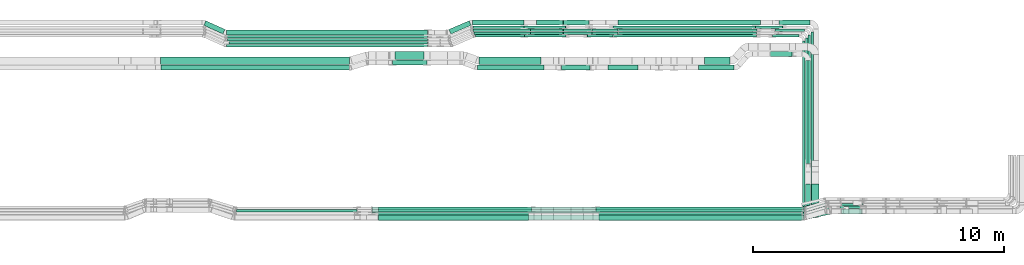
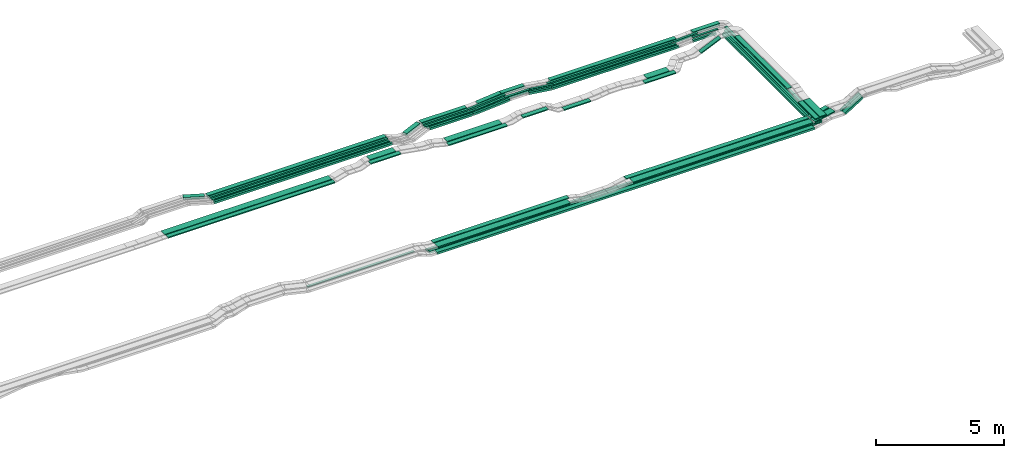
# One storey, part 2 of 31: 64 flow segments.
"""IFC2X3 building model written with IfcOpenShell, lengths in millimetres."""

from ifc_helpers import new_model, entity, si_unit, converted_unit, derived_unit, direction, frame, frame_2d, origin, origin_2d_with_axis, place, context, subcontext, project, spatial, rectangle, extrude, type_object, element, save


model = new_model("IFC2X3")

# Units and contexts
model_context = context("Model", 3, precision=0.01, world=origin(), true_north=direction((6.12303176911189e-17, 1.0)))
body_context = subcontext(model_context, "Body", "Model", "MODEL_VIEW")
ifc_project = project(units=[si_unit("LENGTHUNIT", "METRE", prefix="MILLI"), si_unit("AREAUNIT", "SQUARE_METRE"), si_unit("VOLUMEUNIT", "CUBIC_METRE"), converted_unit("PLANEANGLEUNIT", "DEGREE", entity("IfcRatioMeasure", 0.0174532925199433), si_unit("PLANEANGLEUNIT", "RADIAN"), dimensions=[0, 0, 0, 0, 0, 0, 0]), si_unit("MASSUNIT", "GRAM", prefix="KILO"), derived_unit("MASSDENSITYUNIT", [(si_unit("MASSUNIT", "GRAM", prefix="KILO"), 1), (si_unit("LENGTHUNIT", "METRE"), -3)]), derived_unit("MOMENTOFINERTIAUNIT", [(si_unit("LENGTHUNIT", "METRE"), 4)]), si_unit("TIMEUNIT", "SECOND"), si_unit("FREQUENCYUNIT", "HERTZ"), si_unit("THERMODYNAMICTEMPERATUREUNIT", "DEGREE_CELSIUS"), derived_unit("THERMALTRANSMITTANCEUNIT", [(si_unit("MASSUNIT", "GRAM", prefix="KILO"), 1), (si_unit("THERMODYNAMICTEMPERATUREUNIT", "KELVIN"), -1), (si_unit("TIMEUNIT", "SECOND"), -3)]), derived_unit("VOLUMETRICFLOWRATEUNIT", [(si_unit("LENGTHUNIT", "METRE"), 3), (si_unit("TIMEUNIT", "SECOND"), -1)]), derived_unit("MASSFLOWRATEUNIT", [(si_unit("MASSUNIT", "GRAM", prefix="KILO"), 1), (si_unit("TIMEUNIT", "SECOND"), -1)]), derived_unit("ROTATIONALFREQUENCYUNIT", [(si_unit("TIMEUNIT", "SECOND"), -1)]), si_unit("ELECTRICCURRENTUNIT", "AMPERE"), si_unit("ELECTRICVOLTAGEUNIT", "VOLT"), si_unit("POWERUNIT", "WATT"), si_unit("FORCEUNIT", "NEWTON", prefix="KILO"), si_unit("ILLUMINANCEUNIT", "LUX"), si_unit("LUMINOUSFLUXUNIT", "LUMEN"), si_unit("LUMINOUSINTENSITYUNIT", "CANDELA"), derived_unit("USERDEFINED", [(si_unit("MASSUNIT", "GRAM", prefix="KILO"), -1), (si_unit("LENGTHUNIT", "METRE"), -2), (si_unit("TIMEUNIT", "SECOND"), 3), (si_unit("LUMINOUSFLUXUNIT", "LUMEN"), 1)]), derived_unit("LINEARVELOCITYUNIT", [(si_unit("LENGTHUNIT", "METRE"), 1), (si_unit("TIMEUNIT", "SECOND"), -1)]), si_unit("PRESSUREUNIT", "PASCAL"), derived_unit("USERDEFINED", [(si_unit("LENGTHUNIT", "METRE"), -2), (si_unit("MASSUNIT", "GRAM", prefix="KILO"), 1), (si_unit("TIMEUNIT", "SECOND"), -2)]), derived_unit("LINEARFORCEUNIT", [(si_unit("MASSUNIT", "GRAM", prefix="KILO"), 1), (si_unit("LENGTHUNIT", "METRE"), 1), (si_unit("TIMEUNIT", "SECOND"), -2), (si_unit("LENGTHUNIT", "METRE"), -1)]), derived_unit("PLANARFORCEUNIT", [(si_unit("MASSUNIT", "GRAM", prefix="KILO"), 1), (si_unit("LENGTHUNIT", "METRE"), 1), (si_unit("TIMEUNIT", "SECOND"), -2), (si_unit("LENGTHUNIT", "METRE"), -2)])], contexts=[model_context])

# Site, building, storey
site_placement = place(None, frame((0.0, -0.00077364408347762, 0.0)))
site = spatial("IfcSite", under=ifc_project, at=site_placement, CompositionType="ELEMENT")
building_placement = place(site_placement, origin())
building = spatial("IfcBuilding", under=site, at=building_placement, CompositionType="ELEMENT")
storey_placement = place(building_placement, frame((0.0, 0.0, 15900.0)))
storey = spatial("IfcBuildingStorey", under=building, at=storey_placement, CompositionType="ELEMENT", Elevation=15900.0)

# Flow segments
cable_carrier_segment_type = type_object("IfcCableCarrierSegmentType", PredefinedType="CABLETRAYSEGMENT")
flow_segment_1_placement = place(storey_placement, frame((60126.0767428682, 8284.99390899462, 2660.0)))
element("IfcFlowSegment", 1, at=flow_segment_1_placement, inside=storey, type_object=cable_carrier_segment_type, context=body_context, shape_type="SweptSolid", body=[
    extrude(rectangle(XDim=7079.00000000001, YDim=99.9999999999946, at=frame_2d((-6.82121026329696e-13, 0.0), x_axis=(1.0, 0.0))), frame((50.0, 3539.50000000001, 0.0), z_axis=(0.0, 0.0, 1.0), x_axis=(0.0, -1.0, 0.0)), (0.0, 0.0, 1.0), 99.9999999999989),
])
flow_segment_2_placement = place(storey_placement, frame((60236.0767428682, 8299.45800005181, 2660.19015606754)))
element("IfcFlowSegment", 2, at=flow_segment_2_placement, inside=storey, type_object=cable_carrier_segment_type, context=body_context, shape_type="SweptSolid", body=[
    extrude(rectangle(XDim=7179.00000000001, YDim=99.9999999999946, at=origin_2d_with_axis()), frame((50.0, 3589.50000000001, 0.0), z_axis=(0.0, 0.0, 1.0), x_axis=(0.0, -1.0, 0.0)), (0.0, 0.0, 1.0), 50.0000000000016),
])
flow_segment_3_placement = place(storey_placement, frame((60346.0767428682, 8299.99390899457, 2660.1950842816)))
element("IfcFlowSegment", 3, at=flow_segment_3_placement, inside=storey, type_object=cable_carrier_segment_type, context=body_context, shape_type="SweptSolid", body=[
    extrude(rectangle(XDim=7298.46409105725, YDim=99.9999999999946, at=frame_2d((1.13686837721616e-12, 0.0), x_axis=(1.0, 0.0))), frame((50.0, 3649.23204552863, 0.0), z_axis=(0.0, 0.0, 1.0), x_axis=(0.0, -1.0, 0.0)), (0.0, 0.0, 1.0), 50.0000000000016),
])
flow_segment_4_placement = place(storey_placement, frame((37560.2402796495, 8544.96624585789, 2710.63734545372)))
element("IfcFlowSegment", 4, at=flow_segment_4_placement, inside=storey, type_object=cable_carrier_segment_type, context=body_context, shape_type="SweptSolid", body=[
    extrude(rectangle(XDim=4809.76682509451, YDim=100.000000000001, at=frame_2d((-4.32009983342141e-12, 5.43565192856477e-13), x_axis=(1.0, 0.0))), frame((2404.88341254725, 50.0, 0.0), z_axis=(0.0, 0.0, 1.0), x_axis=(-1.0, 0.0, 0.0)), (0.0, 0.0, 1.0), 50.0000000000016),
])
flow_segment_5_placement = place(storey_placement, frame((43221.6769225087, 8550.14880665483, 2820.0)))
element("IfcFlowSegment", 5, at=flow_segment_5_placement, inside=storey, type_object=cable_carrier_segment_type, context=body_context, shape_type="SweptSolid", body=[
    extrude(rectangle(XDim=6093.02235435077, YDim=200.0, at=origin_2d_with_axis()), frame((3046.51117717539, 100.0, 0.0), z_axis=(0.0, 0.0, 1.0), x_axis=(-1.0, 0.0, 0.0)), (0.0, 0.0, 1.0), 50.0000000000016),
])
flow_segment_6_placement = place(storey_placement, frame((43231.4788097309, 8215.14880665483, 2820.0)))
element("IfcFlowSegment", 6, at=flow_segment_6_placement, inside=storey, type_object=cable_carrier_segment_type, context=body_context, shape_type="SweptSolid", body=[
    extrude(rectangle(XDim=5963.81419063151, YDim=300.000000000001, at=frame_2d((4.32009983342141e-12, 5.40012479177676e-13), x_axis=(1.0, 0.0))), frame((2981.90709531576, 150.0, 0.0), z_axis=(0.0, 0.0, 1.0), x_axis=(-1.0, 0.0, 0.0)), (0.0, 0.0, 1.0), 50.0000000000016),
])
flow_segment_7_placement = place(storey_placement, frame((51889.3819158847, 8550.14880665474, 2820.0)))
element("IfcFlowSegment", 7, at=flow_segment_7_placement, inside=storey, type_object=cable_carrier_segment_type, context=body_context, shape_type="SweptSolid", body=[
    extrude(rectangle(XDim=8214.82266002888, YDim=200.0, at=origin_2d_with_axis()), frame((4107.41133001444, 100.0, 0.0)), (0.0, 0.0, 1.0), 50.0000000000016),
])
flow_segment_8_placement = place(storey_placement, frame((52008.9391584267, 8215.14880665474, 2820.0)))
element("IfcFlowSegment", 8, at=flow_segment_8_placement, inside=storey, type_object=cable_carrier_segment_type, context=body_context, shape_type="SweptSolid", body=[
    extrude(rectangle(XDim=8089.55955573693, YDim=300.000000000001, at=origin_2d_with_axis()), frame((4044.77977786846, 150.0, 0.0)), (0.0, 0.0, 1.0), 50.0000000000016),
])
flow_segment_9_placement = place(storey_placement, frame((42966.1590271839, 8654.96624585788, 2495.02366929601)))
element("IfcFlowSegment", 9, at=flow_segment_9_placement, inside=storey, type_object=cable_carrier_segment_type, context=body_context, shape_type="SweptSolid", body=[
    extrude(rectangle(XDim=17232.0585205176, YDim=100.000000000001, at=frame_2d((-3.63797880709171e-12, 5.43565192856477e-13), x_axis=(1.0, 0.0))), frame((8616.02926025879, 50.0, 0.0)), (0.0, 0.0, 1.0), 50.0000000000016),
])
flow_segment_10_placement = place(storey_placement, frame((42969.9115447475, 8544.96624585788, 2495.0546523344)))
element("IfcFlowSegment", 10, at=flow_segment_10_placement, inside=storey, type_object=cable_carrier_segment_type, context=body_context, shape_type="SweptSolid", body=[
    extrude(rectangle(XDim=17228.3060029539, YDim=100.000000000001, at=frame_2d((-4.54747350886464e-12, 5.43565192856477e-13), x_axis=(1.0, 0.0))), frame((8614.15300147695, 50.0, 0.0)), (0.0, 0.0, 1.0), 50.0000000000016),
])
flow_segment_11_placement = place(storey_placement, frame((42969.0456174009, 8434.96624585777, 2500.0)))
element("IfcFlowSegment", 11, at=flow_segment_11_placement, inside=storey, type_object=cable_carrier_segment_type, context=body_context, shape_type="SweptSolid", body=[
    extrude(rectangle(XDim=17229.1719303005, YDim=99.9999999999989, at=origin_2d_with_axis()), frame((8614.58596515024, 50.0, 0.0)), (0.0, 0.0, 1.0), 99.9999999999989),
])
flow_segment_12_placement = place(storey_placement, frame((43203.4612084207, 8224.96624585778, 2500.0)))
element("IfcFlowSegment", 12, at=flow_segment_12_placement, inside=storey, type_object=cable_carrier_segment_type, context=body_context, shape_type="SweptSolid", body=[
    extrude(rectangle(XDim=16981.1662330708, YDim=200.0, at=frame_2d((-4.54747350886464e-12, -5.47117906535277e-13), x_axis=(1.0, 0.0))), frame((8490.58311653538, 100.0, 0.0)), (0.0, 0.0, 1.0), 99.9999999999968),
])
flow_segment_13_placement = place(storey_placement, frame((60142.3221565162, 8560.70428769461, 2820.0)))
element("IfcFlowSegment", 13, at=flow_segment_13_placement, inside=storey, type_object=cable_carrier_segment_type, context=body_context, shape_type="SweptSolid", body=[
    extrude(rectangle(XDim=974.281376760203, YDim=200.000000000001, at=frame_2d((-1.4210854715202e-13, -5.40012479177676e-13), x_axis=(1.0, 0.0))), frame((496.882685052164, 214.444327228766, 0.0), z_axis=(0.0, 0.0, 1.0), x_axis=(-0.970529997992859, -0.240980337363821, 0.0)), (0.0, 0.0, 1.0), 50.0000000000016),
])
flow_segment_14_placement = place(storey_placement, frame((60133.7239929422, 8226.56545636169, 2820.0)))
element("IfcFlowSegment", 14, at=flow_segment_14_placement, inside=storey, type_object=cable_carrier_segment_type, context=body_context, shape_type="SweptSolid", body=[
    extrude(rectangle(XDim=1058.47458946237, YDim=300.000000000004, at=origin_2d_with_axis()), frame((549.321224610694, 263.583158561679, 0.0), z_axis=(0.0, 0.0, 1.0), x_axis=(-0.975122262229243, -0.221667710108901, 0.0)), (0.0, 0.0, 1.0), 50.0000000000016),
])
flow_segment_15_placement = place(storey_placement, frame((34536.9675359055, 14435.0255085139, 2675.0)))
element("IfcFlowSegment", 15, at=flow_segment_15_placement, inside=storey, type_object=cable_carrier_segment_type, context=body_context, shape_type="SweptSolid", body=[
    extrude(rectangle(XDim=7521.02349391717, YDim=300.000000000001, at=frame_2d((-2.27373675443232e-12, 0.0), x_axis=(1.0, 0.0))), frame((3760.51174695859, 150.0, 0.0), z_axis=(0.0, 0.0, 1.0), x_axis=(-1.0, 0.0, 0.0)), (0.0, 0.0, 1.0), 50.0000000000016),
])
flow_segment_16_placement = place(storey_placement, frame((34556.9248240395, 14200.0255085139, 2675.0)))
element("IfcFlowSegment", 16, at=flow_segment_16_placement, inside=storey, type_object=cable_carrier_segment_type, context=body_context, shape_type="SweptSolid", body=[
    extrude(rectangle(XDim=7508.26665724989, YDim=199.999999999998, at=origin_2d_with_axis()), frame((3754.13332862494, 100.0, 0.0), z_axis=(0.0, 0.0, 1.0), x_axis=(-1.0, 0.0, 0.0)), (0.0, 0.0, 1.0), 50.0000000000016),
])
flow_segment_17_placement = place(storey_placement, frame((47238.0928081156, 14435.0255085139, 2650.0)))
element("IfcFlowSegment", 17, at=flow_segment_17_placement, inside=storey, type_object=cable_carrier_segment_type, context=body_context, shape_type="SweptSolid", body=[
    extrude(rectangle(XDim=2472.10759373964, YDim=300.000000000001, at=frame_2d((0.0, 1.08002495835535e-12), x_axis=(1.0, 0.0))), frame((1236.05379686982, 150.0, 0.0)), (0.0, 0.0, 1.0), 50.0000000000016),
])
flow_segment_18_placement = place(storey_placement, frame((37169.4687962586, 15609.9939089947, 2835.0)))
element("IfcFlowSegment", 18, at=flow_segment_18_placement, inside=storey, type_object=cable_carrier_segment_type, context=body_context, shape_type="SweptSolid", body=[
    extrude(rectangle(XDim=8013.73124229196, YDim=200.000000000002, at=frame_2d((-4.32009983342141e-12, 0.0), x_axis=(1.0, 0.0))), frame((4006.86562114598, 100.0, 0.0)), (0.0, 0.0, 1.0), 99.9999999999989),
])
flow_segment_19_placement = place(storey_placement, frame((37186.1261928913, 15479.9939089947, 2835.0)))
element("IfcFlowSegment", 19, at=flow_segment_19_placement, inside=storey, type_object=cable_carrier_segment_type, context=body_context, shape_type="SweptSolid", body=[
    extrude(rectangle(XDim=7996.88069095725, YDim=99.9999999999989, at=frame_2d((-2.27373675443232e-12, 1.08357767203415e-12), x_axis=(1.0, 0.0))), frame((3998.44034547862, 50.0, 0.0)), (0.0, 0.0, 1.0), 99.9999999999989),
])
flow_segment_20_placement = place(storey_placement, frame((37201.5450950808, 15359.4580000518, 2838.00113012667)))
element("IfcFlowSegment", 20, at=flow_segment_20_placement, inside=storey, type_object=cable_carrier_segment_type, context=body_context, shape_type="SweptSolid", body=[
    extrude(rectangle(XDim=7980.27118863344, YDim=99.9999999999989, at=frame_2d((-2.04636307898909e-12, -1.08357767203415e-12), x_axis=(1.0, 0.0))), frame((3990.13559431672, 50.0, 0.0)), (0.0, 0.0, 1.0), 50.0000000000016),
])
flow_segment_21_placement = place(storey_placement, frame((37267.0183213648, 15239.4580000518, 2838.00113012699)))
element("IfcFlowSegment", 21, at=flow_segment_21_placement, inside=storey, type_object=cable_carrier_segment_type, context=body_context, shape_type="SweptSolid", body=[
    extrude(rectangle(XDim=7914.79796234961, YDim=99.9999999999989, at=frame_2d((0.0, 1.08357767203415e-12), x_axis=(1.0, 0.0))), frame((3957.3989811748, 50.0, 0.0)), (0.0, 0.0, 1.0), 50.0000000000016),
])
flow_segment_22_placement = place(storey_placement, frame((37164.5534838252, 15124.9939089947, 2834.95683445176)))
element("IfcFlowSegment", 22, at=flow_segment_22_placement, inside=storey, type_object=cable_carrier_segment_type, context=body_context, shape_type="SweptSolid", body=[
    extrude(rectangle(XDim=8018.77837251078, YDim=99.9999999999989, at=frame_2d((-4.32009983342141e-12, 0.0), x_axis=(1.0, 0.0))), frame((4009.38918625539, 50.0, 0.0), z_axis=(0.0, 0.0, 1.0), x_axis=(-1.0, 0.0, 0.0)), (0.0, 0.0, 1.0), 99.9999999999989),
])
flow_segment_23_placement = place(storey_placement, frame((46977.5480949237, 15999.9939089947, 2635.0)))
element("IfcFlowSegment", 23, at=flow_segment_23_placement, inside=storey, type_object=cable_carrier_segment_type, context=body_context, shape_type="SweptSolid", body=[
    extrude(rectangle(XDim=2052.75232011683, YDim=199.999999999998, at=frame_2d((4.32009983342141e-12, 1.08002495835535e-12), x_axis=(1.0, 0.0))), frame((1026.37616005842, 100.0, 0.0)), (0.0, 0.0, 1.0), 99.9999999999989),
])
flow_segment_24_placement = place(storey_placement, frame((46985.5606503717, 15869.9939089947, 2635.0)))
element("IfcFlowSegment", 24, at=flow_segment_24_placement, inside=storey, type_object=cable_carrier_segment_type, context=body_context, shape_type="SweptSolid", body=[
    extrude(rectangle(XDim=2041.44898293753, YDim=99.9999999999989, at=frame_2d((4.32009983342141e-12, 1.08357767203415e-12), x_axis=(1.0, 0.0))), frame((1020.72449146877, 50.0, 0.0)), (0.0, 0.0, 1.0), 99.9999999999989),
])
flow_segment_25_placement = place(storey_placement, frame((46985.5606503717, 15749.4580000518, 2637.24472037611)))
element("IfcFlowSegment", 25, at=flow_segment_25_placement, inside=storey, type_object=cable_carrier_segment_type, context=body_context, shape_type="SweptSolid", body=[
    extrude(rectangle(XDim=2290.66032248258, YDim=99.9999999999989, at=frame_2d((0.0, 1.08357767203415e-12), x_axis=(1.0, 0.0))), frame((1145.33016124129, 50.0, 0.0)), (0.0, 0.0, 1.0), 50.0000000000016),
])
flow_segment_26_placement = place(storey_placement, frame((47028.2259722805, 15629.4580000518, 2637.24472037609)))
element("IfcFlowSegment", 26, at=flow_segment_26_placement, inside=storey, type_object=cable_carrier_segment_type, context=body_context, shape_type="SweptSolid", body=[
    extrude(rectangle(XDim=2247.99500057377, YDim=99.9999999999989, at=frame_2d((0.0, 1.08357767203415e-12), x_axis=(1.0, 0.0))), frame((1123.99750028689, 50.0, 0.0), z_axis=(0.0, 0.0, 1.0), x_axis=(-1.0, 0.0, 0.0)), (0.0, 0.0, 1.0), 50.0000000000016),
])
flow_segment_27_placement = place(storey_placement, frame((47088.2259722794, 15514.9939089947, 2634.94956318967)))
element("IfcFlowSegment", 27, at=flow_segment_27_placement, inside=storey, type_object=cable_carrier_segment_type, context=body_context, shape_type="SweptSolid", body=[
    extrude(rectangle(XDim=1946.15966005004, YDim=99.9999999999989, at=frame_2d((4.32009983342141e-12, 1.08357767203415e-12), x_axis=(1.0, 0.0))), frame((973.079830025015, 50.0, 0.0), z_axis=(0.0, 0.0, 1.0), x_axis=(-1.0, 0.0, 0.0)), (0.0, 0.0, 1.0), 99.9999999999989),
])
flow_segment_28_placement = place(storey_placement, frame((50592.288789294, 15999.9939089947, 2760.0)))
element("IfcFlowSegment", 28, at=flow_segment_28_placement, inside=storey, type_object=cable_carrier_segment_type, context=body_context, shape_type="SweptSolid", body=[
    extrude(rectangle(XDim=1023.30452444504, YDim=200.000000000002, at=frame_2d((0.0, 1.08713038571295e-12), x_axis=(1.0, 0.0))), frame((511.65226222252, 100.0, 0.0), z_axis=(0.0, 0.0, 1.0), x_axis=(-1.0, 0.0, 0.0)), (0.0, 0.0, 1.0), 99.9999999999989),
])
flow_segment_29_placement = place(storey_placement, frame((50590.7420026315, 15749.4580000518, 2762.19977544195)))
element("IfcFlowSegment", 29, at=flow_segment_29_placement, inside=storey, type_object=cable_carrier_segment_type, context=body_context, shape_type="SweptSolid", body=[
    extrude(rectangle(XDim=1131.59489516369, YDim=99.9999999999989, at=origin_2d_with_axis()), frame((565.797447581843, 50.0, 0.0), z_axis=(0.0, 0.0, 1.0), x_axis=(-1.0, 0.0, 0.0)), (0.0, 0.0, 1.0), 50.0000000000016),
])
flow_segment_30_placement = place(storey_placement, frame((50590.7420026315, 15629.4580000518, 2762.19977544195)))
element("IfcFlowSegment", 30, at=flow_segment_30_placement, inside=storey, type_object=cable_carrier_segment_type, context=body_context, shape_type="SweptSolid", body=[
    extrude(rectangle(XDim=1135.49890513971, YDim=99.9999999999989, at=frame_2d((-4.32009983342141e-12, 0.0), x_axis=(1.0, 0.0))), frame((567.749452569852, 50.0, 0.0), z_axis=(0.0, 0.0, 1.0), x_axis=(-1.0, 0.0, 0.0)), (0.0, 0.0, 1.0), 50.0000000000016),
])
flow_segment_31_placement = place(storey_placement, frame((52778.7987899668, 15999.9939089946, 2615.0)))
element("IfcFlowSegment", 31, at=flow_segment_31_placement, inside=storey, type_object=cable_carrier_segment_type, context=body_context, shape_type="SweptSolid", body=[
    extrude(rectangle(XDim=5664.14517649834, YDim=200.000000000002, at=origin_2d_with_axis()), frame((2832.07258824917, 100.0, 0.0)), (0.0, 0.0, 1.0), 100.000000000001),
])
flow_segment_32_placement = place(storey_placement, frame((52567.1472057235, 15869.9939089946, 2615.0)))
element("IfcFlowSegment", 32, at=flow_segment_32_placement, inside=storey, type_object=cable_carrier_segment_type, context=body_context, shape_type="SweptSolid", body=[
    extrude(rectangle(XDim=5684.09323348246, YDim=99.9999999999989, at=frame_2d((4.32009983342141e-12, 2.16715534406831e-12), x_axis=(1.0, 0.0))), frame((2842.04661674123, 50.0, 0.0)), (0.0, 0.0, 1.0), 99.9999999999989),
])
flow_segment_33_placement = place(storey_placement, frame((52780.8073283255, 15749.4580000518, 2617.36207118773)))
element("IfcFlowSegment", 33, at=flow_segment_33_placement, inside=storey, type_object=cable_carrier_segment_type, context=body_context, shape_type="SweptSolid", body=[
    extrude(rectangle(XDim=5535.15002954218, YDim=99.9999999999989, at=frame_2d((0.0, -1.08357767203415e-12), x_axis=(1.0, 0.0))), frame((2767.57501477109, 50.0, 0.0)), (0.0, 0.0, 1.0), 50.0000000000016),
])
flow_segment_34_placement = place(storey_placement, frame((52780.8123396358, 15629.4580000518, 2617.36325714286)))
element("IfcFlowSegment", 34, at=flow_segment_34_placement, inside=storey, type_object=cable_carrier_segment_type, context=body_context, shape_type="SweptSolid", body=[
    extrude(rectangle(XDim=5506.546574727, YDim=99.9999999999989, at=frame_2d((-4.32009983342141e-12, 0.0), x_axis=(1.0, 0.0))), frame((2753.27328736351, 50.0, 0.0)), (0.0, 0.0, 1.0), 50.0000000000016),
])
flow_segment_35_placement = place(storey_placement, frame((52583.1988011515, 15514.9939089947, 2617.02711976826)))
element("IfcFlowSegment", 35, at=flow_segment_35_placement, inside=storey, type_object=cable_carrier_segment_type, context=body_context, shape_type="SweptSolid", body=[
    extrude(rectangle(XDim=5712.42683237125, YDim=99.9999999999989, at=frame_2d((0.0, 2.16715534406831e-12), x_axis=(1.0, 0.0))), frame((2856.21341618563, 50.0, 0.0)), (0.0, 0.0, 1.0), 99.9999999999989),
])
flow_segment_36_placement = place(storey_placement, frame((49278.5963398133, 15629.4580000518, 2637.58377383959)))
element("IfcFlowSegment", 36, at=flow_segment_36_placement, inside=storey, type_object=cable_carrier_segment_type, context=body_context, shape_type="SweptSolid", body=[
    extrude(rectangle(XDim=50.0000000000012, YDim=99.9999999999989, at=origin_2d_with_axis()), frame((2.37429369247075, 50.0, 24.886999205648), z_axis=(0.995479968225896, 0.0, 0.0949717476988276), x_axis=(-0.0949717476988276, 0.0, 0.995479968225896)), (0.0, 0.0, 1.0), 1310.94723161525),
])
flow_segment_37_placement = place(storey_placement, frame((51728.7788093729, 15629.4580000518, 2618.00795340448)))
element("IfcFlowSegment", 37, at=flow_segment_37_placement, inside=storey, type_object=cable_carrier_segment_type, context=body_context, shape_type="SweptSolid", body=[
    extrude(rectangle(XDim=50.0000000000022, YDim=99.9999999999989, at=origin_2d_with_axis()), frame((3.42066621577717, 50.0, 168.782250596679), z_axis=(0.9905950071671, 0.0, -0.136826648631081), x_axis=(0.136826648631081, 0.0, 0.9905950071671)), (0.0, 0.0, 1.0), 1052.55355486941),
])
flow_segment_38_placement = place(storey_placement, frame((49278.5963398133, 15749.4580000518, 2637.58377383961)))
element("IfcFlowSegment", 38, at=flow_segment_38_placement, inside=storey, type_object=cable_carrier_segment_type, context=body_context, shape_type="SweptSolid", body=[
    extrude(rectangle(XDim=50.0000000000012, YDim=99.9999999999989, at=origin_2d_with_axis()), frame((2.37429369247075, 50.0, 24.8869992056501), z_axis=(0.995479968225896, 0.0, 0.0949717476988276), x_axis=(-0.0949717476988276, 0.0, 0.995479968225896)), (0.0, 0.0, 1.0), 1310.94723161524),
])
flow_segment_39_placement = place(storey_placement, frame((51724.8728752329, 15749.4580000518, 2618.00256006421)))
element("IfcFlowSegment", 39, at=flow_segment_39_placement, inside=storey, type_object=cable_carrier_segment_type, context=body_context, shape_type="SweptSolid", body=[
    extrude(rectangle(XDim=49.9999999999997, YDim=99.9999999999989, at=frame_2d((2.1440627051561e-12, 0.0), x_axis=(1.0, 0.0))), frame((3.40821088898738, 50.0, 168.79013411279), z_axis=(0.990663695538499, 0.0, -0.136328435559149), x_axis=(0.136328435559149, 0.0, 0.990663695538499)), (0.0, 0.0, 1.0), 1056.44534930489),
])
flow_segment_40_placement = place(storey_placement, frame((49029.3066962633, 15869.9939089947, 2635.36764150382)))
element("IfcFlowSegment", 40, at=flow_segment_40_placement, inside=storey, type_object=cable_carrier_segment_type, context=body_context, shape_type="SweptSolid", body=[
    extrude(rectangle(XDim=100.000000000002, YDim=99.9999999999989, at=frame_2d((0.0, -2.1564972030319e-12), x_axis=(0.0, 1.0))), frame((3.74846387589776, 50.0, 49.8592921988609), z_axis=(0.997185843977158, 0.0, 0.0749692775179538), x_axis=(0.0, 1.0, 0.0)), (0.0, 0.0, 1.0), 1661.29562292556),
])
flow_segment_41_placement = place(storey_placement, frame((49520.8032402706, 15999.9939089947, 2658.79671788514)))
element("IfcFlowSegment", 41, at=flow_segment_41_placement, inside=storey, type_object=cable_carrier_segment_type, context=body_context, shape_type="SweptSolid", body=[
    extrude(rectangle(XDim=99.9999999999997, YDim=199.999999999998, at=origin_2d_with_axis()), frame((4.74858738495016, 100.0, 49.7739984112938), z_axis=(0.995479968225879, 0.0, 0.0949717476990034), x_axis=(-0.0949717476990034, 0.0, 0.995479968225879)), (0.0, 0.0, 1.0), 1064.42423867442),
])
flow_segment_42_placement = place(storey_placement, frame((43889.7178807035, 14635.0255085139, 2835.0)))
element("IfcFlowSegment", 42, at=flow_segment_42_placement, inside=storey, type_object=cable_carrier_segment_type, context=body_context, shape_type="SweptSolid", body=[
    extrude(rectangle(XDim=1151.72101065198, YDim=300.000000000001, at=frame_2d((-4.37694325228222e-12, 1.08002495835535e-12), x_axis=(1.0, 0.0))), frame((575.860505325993, 150.0, 0.0)), (0.0, 0.0, 1.0), 50.0000000000016),
])
flow_segment_43_placement = place(storey_placement, frame((43781.9090436039, 14400.0255085139, 2835.0)))
element("IfcFlowSegment", 43, at=flow_segment_43_placement, inside=storey, type_object=cable_carrier_segment_type, context=body_context, shape_type="SweptSolid", body=[
    extrude(rectangle(XDim=1369.74391930187, YDim=199.999999999998, at=frame_2d((4.32009983342141e-12, -1.08002495835535e-12), x_axis=(1.0, 0.0))), frame((684.87195965093, 100.0, 0.0)), (0.0, 0.0, 1.0), 50.0000000000016),
])
flow_segment_44_placement = place(storey_placement, frame((47168.7312965343, 14200.0255085139, 2650.0)))
element("IfcFlowSegment", 44, at=flow_segment_44_placement, inside=storey, type_object=cable_carrier_segment_type, context=body_context, shape_type="SweptSolid", body=[
    extrude(rectangle(XDim=2650.06252227778, YDim=200.000000000002, at=frame_2d((0.0, 1.08713038571295e-12), x_axis=(1.0, 0.0))), frame((1325.03126113889, 100.0, 0.0)), (0.0, 0.0, 1.0), 50.0000000000016),
])
flow_segment_45_placement = place(storey_placement, frame((49036.6828370256, 15514.9939089947, 2635.31752324906)))
element("IfcFlowSegment", 45, at=flow_segment_45_placement, inside=storey, type_object=cable_carrier_segment_type, context=body_context, shape_type="SweptSolid", body=[
    extrude(rectangle(XDim=99.9999999999993, YDim=99.9999999999989, at=origin_2d_with_axis()), frame((3.75026960239425, 50.0, 49.8591564099239), z_axis=(0.997183128198485, 0.0, 0.0750053920480587), x_axis=(-0.0750053920480587, 0.0, 0.997183128198485)), (0.0, 0.0, 1.0), 1655.9166479278),
])
flow_segment_46_placement = place(storey_placement, frame((51544.0698207102, 15514.9939089947, 2618.14206567148)))
element("IfcFlowSegment", 46, at=flow_segment_46_placement, inside=storey, type_object=cable_carrier_segment_type, context=body_context, shape_type="SweptSolid", body=[
    extrude(rectangle(XDim=100.0, YDim=99.9999999999989, at=origin_2d_with_axis()), frame((6.84133243155434, 50.0, 190.819711571931), z_axis=(0.990595007167099, 0.0, -0.136826648631087), x_axis=(0.136826648631087, 0.0, 0.990595007167099)), (0.0, 0.0, 1.0), 1032.6201995526),
])
flow_segment_47_placement = place(storey_placement, frame((46030.0003936025, 15639.0430440655, 2635.0)))
element("IfcFlowSegment", 47, at=flow_segment_47_placement, inside=storey, type_object=cable_carrier_segment_type, context=body_context, shape_type="SweptSolid", body=[
    extrude(rectangle(XDim=878.885872207849, YDim=199.999999999999, at=frame_2d((3.95061761082616e-12, -1.71240799318184e-12), x_axis=(1.0, 0.0))), frame((443.094644955629, 265.950864929137, 0.0), z_axis=(0.0, 0.0, 1.0), x_axis=(-0.918134666973498, -0.396268511619916, 0.0)), (0.0, 0.0, 1.0), 99.9999999999989),
])
flow_segment_48_placement = place(storey_placement, frame((36260.4035302283, 15641.4607590717, 2835.0)))
element("IfcFlowSegment", 48, at=flow_segment_48_placement, inside=storey, type_object=cable_carrier_segment_type, context=body_context, shape_type="SweptSolid", body=[
    extrude(rectangle(XDim=837.315637086008, YDim=200.0, at=frame_2d((4.54747350886464e-13, -9.9475983006414e-13), x_axis=(1.0, 0.0))), frame((422.691508329828, 263.533149923065, 0.0), z_axis=(0.0, 0.0, 1.0), x_axis=(0.911271304124217, -0.411806520443459, 0.0)), (0.0, 0.0, 1.0), 99.9999999999989),
])
flow_segment_49_placement = place(storey_placement, frame((59189.5267962616, 15999.9939089946, 2660.0)))
element("IfcFlowSegment", 49, at=flow_segment_49_placement, inside=storey, type_object=cable_carrier_segment_type, context=body_context, shape_type="SweptSolid", body=[
    extrude(rectangle(XDim=1225.54994660658, YDim=200.000000000002, at=frame_2d((-4.32009983342141e-12, 1.08713038571295e-12), x_axis=(1.0, 0.0))), frame((612.774973303294, 100.0, 0.0), z_axis=(0.0, 0.0, 1.0), x_axis=(-1.0, 0.0, 0.0)), (0.0, 0.0, 1.0), 99.9999999999989),
])
flow_segment_50_placement = place(storey_placement, frame((59037.940679904, 15749.4580000518, 2660.1950842816)))
element("IfcFlowSegment", 50, at=flow_segment_50_placement, inside=storey, type_object=cable_carrier_segment_type, context=body_context, shape_type="SweptSolid", body=[
    extrude(rectangle(XDim=1157.13606296418, YDim=99.9999999999989, at=frame_2d((0.0, -1.08357767203415e-12), x_axis=(1.0, 0.0))), frame((578.568031482092, 50.0, 0.0), z_axis=(0.0, 0.0, 1.0), x_axis=(-1.0, 0.0, 0.0)), (0.0, 0.0, 1.0), 50.0000000000016),
])
flow_segment_51_placement = place(storey_placement, frame((58923.9406510284, 15514.9939089946, 2660.0)))
element("IfcFlowSegment", 51, at=flow_segment_51_placement, inside=storey, type_object=cable_carrier_segment_type, context=body_context, shape_type="SweptSolid", body=[
    extrude(rectangle(XDim=1051.13609183986, YDim=99.9999999999989, at=frame_2d((0.0, 1.08357767203415e-12), x_axis=(1.0, 0.0))), frame((525.568045919928, 50.0, 0.0), z_axis=(0.0, 0.0, 1.0), x_axis=(-1.0, 0.0, 0.0)), (0.0, 0.0, 1.0), 99.9999999999989),
])
flow_segment_52_placement = place(storey_placement, frame((58253.4051438747, 15869.9939089946, 2615.13051320271)))
element("IfcFlowSegment", 52, at=flow_segment_52_placement, inside=storey, type_object=cable_carrier_segment_type, context=body_context, shape_type="SweptSolid", body=[
    extrude(rectangle(XDim=99.9999999999985, YDim=99.9999999999989, at=frame_2d((0.0, 0.0), x_axis=(0.0, 1.0))), frame((2.06952023444358, 50.0, 49.9571525009101), z_axis=(0.999143050018217, 0.0, 0.0413904046886989), x_axis=(0.0, 1.0, 0.0)), (0.0, 0.0, 1.0), 1082.97246499199),
])
flow_segment_53_placement = place(storey_placement, frame((50520.1476248312, 14200.0255085138, 2790.0)))
element("IfcFlowSegment", 53, at=flow_segment_53_placement, inside=storey, type_object=cable_carrier_segment_type, context=body_context, shape_type="SweptSolid", body=[
    extrude(rectangle(XDim=1135.94756189123, YDim=200.000000000002, at=frame_2d((-4.32009983342141e-12, -1.08713038571295e-12), x_axis=(1.0, 0.0))), frame((567.973780945608, 100.0, 0.0), z_axis=(0.0, 0.0, 1.0), x_axis=(-1.0, 0.0, 0.0)), (0.0, 0.0, 1.0), 50.0000000000016),
])
flow_segment_54_placement = place(storey_placement, frame((52362.8037112791, 14200.0255085138, 2510.0)))
element("IfcFlowSegment", 54, at=flow_segment_54_placement, inside=storey, type_object=cable_carrier_segment_type, context=body_context, shape_type="SweptSolid", body=[
    extrude(rectangle(XDim=1206.14612446976, YDim=200.000000000002, at=frame_2d((0.0, 1.08713038571295e-12), x_axis=(1.0, 0.0))), frame((603.073062234879, 100.0, 0.0)), (0.0, 0.0, 1.0), 50.0000000000016),
])
flow_segment_55_placement = place(storey_placement, frame((56227.7897165469, 14435.0255085138, 2510.0)))
element("IfcFlowSegment", 55, at=flow_segment_55_placement, inside=storey, type_object=cable_carrier_segment_type, context=body_context, shape_type="SweptSolid", body=[
    extrude(rectangle(XDim=1007.78319978753, YDim=300.000000000001, at=frame_2d((-4.34852154285181e-12, 1.08002495835535e-12), x_axis=(1.0, 0.0))), frame((503.891599893779, 150.0, 0.0)), (0.0, 0.0, 1.0), 50.0000000000038),
])
flow_segment_56_placement = place(storey_placement, frame((55987.7592399155, 14200.0255085138, 2510.0)))
element("IfcFlowSegment", 56, at=flow_segment_56_placement, inside=storey, type_object=cable_carrier_segment_type, context=body_context, shape_type="SweptSolid", body=[
    extrude(rectangle(XDim=1407.59439067443, YDim=200.000000000002, at=frame_2d((4.32009983342141e-12, 0.0), x_axis=(1.0, 0.0))), frame((703.79719533721, 100.0, 0.0)), (0.0, 0.0, 1.0), 50.0000000000016),
])
flow_segment_57_placement = place(storey_placement, frame((58823.1038131155, 14740.0255085138, 2615.53742369591)))
element("IfcFlowSegment", 57, at=flow_segment_57_placement, inside=storey, type_object=cable_carrier_segment_type, context=body_context, shape_type="SweptSolid", body=[
    extrude(rectangle(XDim=50.0000000000009, YDim=199.999999999998, at=frame_2d((0.0, 0.0), x_axis=(0.0, 1.0))), frame((10.103600774682, 100.0, 22.8673840083593), z_axis=(0.914695360334444, 0.0, 0.404144030987273), x_axis=(0.0, 1.0, 0.0)), (0.0, 0.0, 1.0), 974.200244285783),
])
flow_segment_58_placement = place(storey_placement, frame((60456.0767428682, 8299.99390899457, 2660.0)))
element("IfcFlowSegment", 58, at=flow_segment_58_placement, inside=storey, type_object=cable_carrier_segment_type, context=body_context, shape_type="SweptSolid", body=[
    extrude(rectangle(XDim=7419.00000000005, YDim=99.9999999999946, at=frame_2d((9.09494701772928e-13, 0.0), x_axis=(1.0, 0.0))), frame((50.0, 3709.50000000002, 0.0), z_axis=(0.0, 0.0, 1.0), x_axis=(0.0, -1.0, 0.0)), (0.0, 0.0, 1.0), 99.9999999999989),
])
flow_segment_59_placement = place(storey_placement, frame((60246.8175590596, 8323.61601629268, 2880.0)))
element("IfcFlowSegment", 59, at=flow_segment_59_placement, inside=storey, type_object=cable_carrier_segment_type, context=body_context, shape_type="SweptSolid", body=[
    extrude(rectangle(XDim=1329.66833027692, YDim=200.000000000007, at=frame_2d((5.11590769747272e-13, 0.0), x_axis=(1.0, 0.0))), frame((100.0, 664.83416513846, 0.0), z_axis=(0.0, 0.0, 1.0), x_axis=(0.0, -1.0, 0.0)), (0.0, 0.0, 1.0), 50.0000000000016),
])
flow_segment_60_placement = place(storey_placement, frame((60480.8175590596, 8363.61601629267, 2880.0)))
element("IfcFlowSegment", 60, at=flow_segment_60_placement, inside=storey, type_object=cable_carrier_segment_type, context=body_context, shape_type="SweptSolid", body=[
    extrude(rectangle(XDim=1289.66833027692, YDim=300.000000000001, at=frame_2d((5.6843418860808e-13, 0.0), x_axis=(1.0, 0.0))), frame((150.0, 644.834165138462, 0.0), z_axis=(0.0, 0.0, 1.0), x_axis=(0.0, -1.0, 0.0)), (0.0, 0.0, 1.0), 50.0000000000016),
])
flow_segment_61_placement = place(storey_placement, frame((60246.8175590596, 10481.671737866, 3010.0)))
element("IfcFlowSegment", 61, at=flow_segment_61_placement, inside=storey, type_object=cable_carrier_segment_type, context=body_context, shape_type="SweptSolid", body=[
    extrude(rectangle(XDim=4107.35377064785, YDim=200.000000000007, at=origin_2d_with_axis()), frame((100.0, 2053.67688532393, 0.0), z_axis=(0.0, 0.0, 1.0), x_axis=(0.0, -1.0, 0.0)), (0.0, 0.0, 1.0), 50.0000000000016),
])
flow_segment_62_placement = place(storey_placement, frame((61669.3708821293, 8474.96586239491, 2516.62940134129)))
element("IfcFlowSegment", 62, at=flow_segment_62_placement, inside=storey, type_object=cable_carrier_segment_type, context=body_context, shape_type="SweptSolid", body=[
    extrude(rectangle(XDim=100.000000000002, YDim=200.0, at=frame_2d((9.13047415451729e-13, 0.0), x_axis=(1.0, 0.0))), frame((26.7193250955396, 100.0, 42.2620120964408), z_axis=(0.845240241928734, 0.0, 0.534386501910608), x_axis=(-0.534386501910608, 0.0, 0.845240241928734)), (0.0, 0.0, 1.0), 949.97195444437),
])
flow_segment_63_placement = place(storey_placement, frame((61620.4165528528, 8684.96586239498, 2514.44731498031)))
element("IfcFlowSegment", 63, at=flow_segment_63_placement, inside=storey, type_object=cable_carrier_segment_type, context=body_context, shape_type="SweptSolid", body=[
    extrude(rectangle(XDim=99.9999999999952, YDim=100.000000000001, at=origin_2d_with_axis()), frame((25.0114283900799, 50.0, 43.2946699939814), z_axis=(0.865893399879649, 0.0, 0.500228567801622), x_axis=(-0.500228567801622, 0.0, 0.865893399879649)), (0.0, 0.0, 1.0), 1019.43607262713),
])
flow_segment_64_placement = place(storey_placement, frame((61680.9800386207, 8794.96586239507, 2511.10446961825)))
element("IfcFlowSegment", 64, at=flow_segment_64_placement, inside=storey, type_object=cable_carrier_segment_type, context=body_context, shape_type="SweptSolid", body=[
    extrude(rectangle(XDim=49.9999999999965, YDim=100.000000000001, at=origin_2d_with_axis()), frame((13.0909688854358, 50.0, 21.2985101272475), z_axis=(0.851940405089958, 0.0, 0.523638755417471), x_axis=(-0.523638755417471, 0.0, 0.851940405089958)), (0.0, 0.0, 1.0), 975.15520337308),
])

save(model, "model.ifc")
